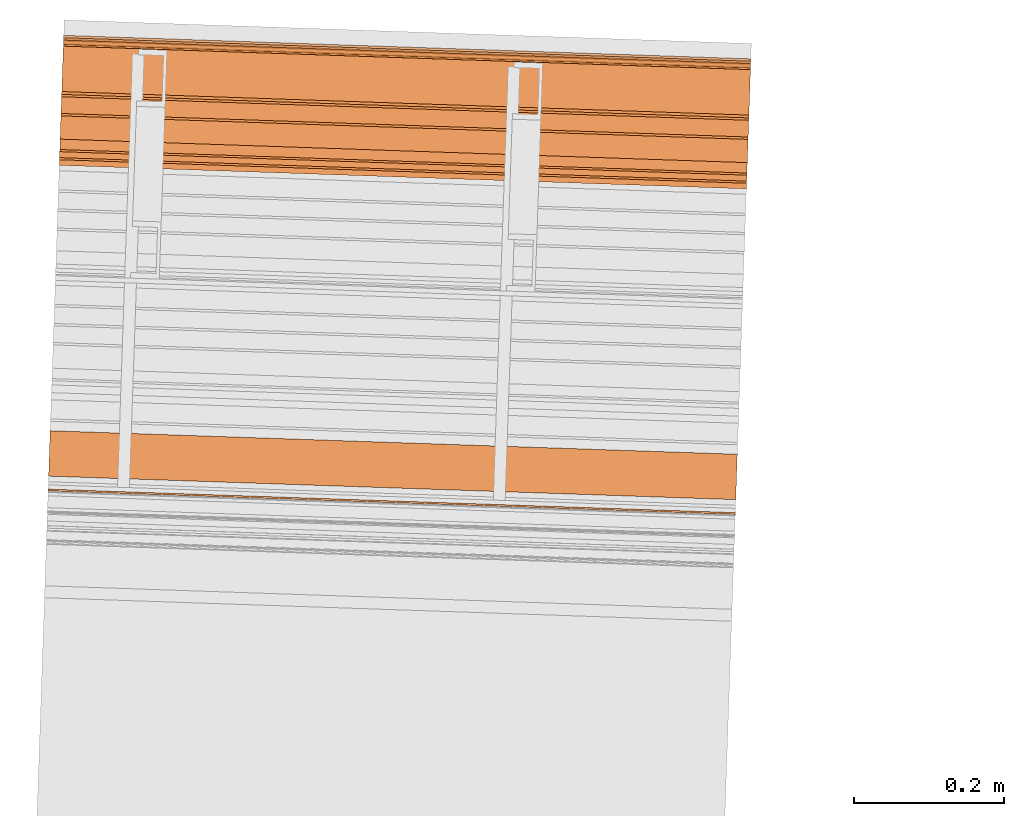
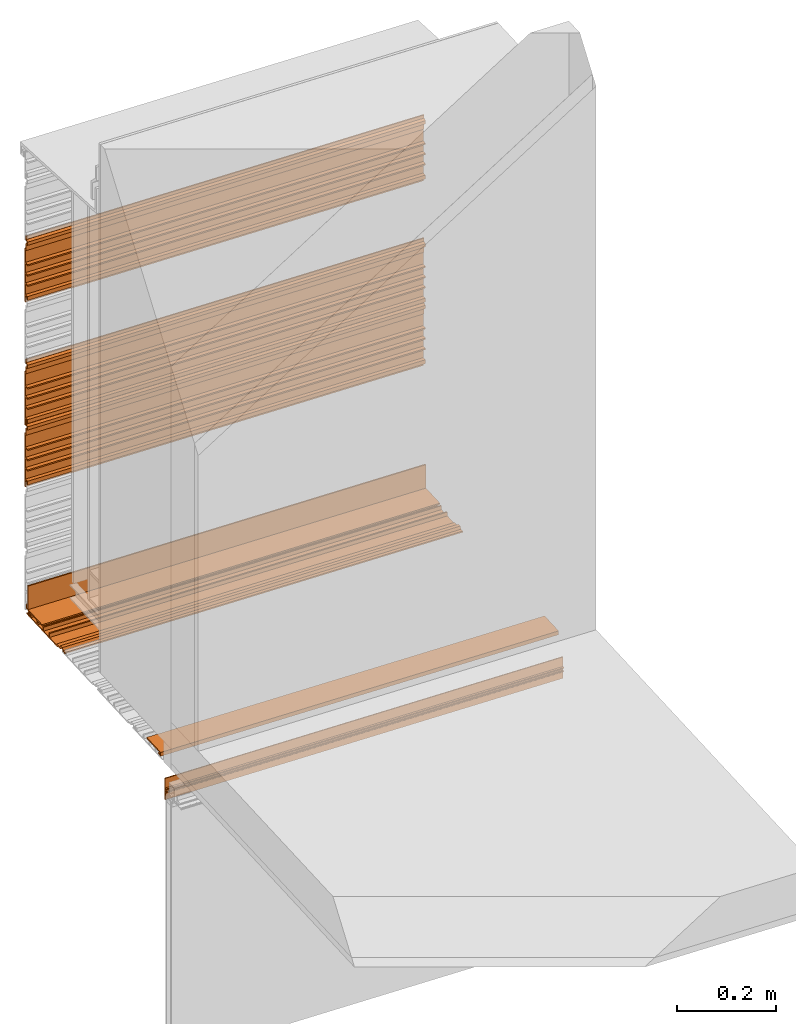
# One storey, part 5 of 6: 8 proxies.
"""IFC2X3 building model written with IfcOpenShell, lengths in feet."""

from ifc_helpers import new_model, entity, si_unit, converted_unit, derived_unit, direction, frame, frame_2d, origin, place, context, subcontext, project, spatial, polyline, circle_curve, parameter, trimmed, segment, composite_curve, outline, extrude, source, transform, mapped, material, type_object, type_shapes, element, save


model = new_model("IFC2X3")

# Units and contexts
model_context = context("Model", 3, precision=0.0001, world=origin(), true_north=direction((6.12303176911189e-17, 1.0)))
context_of_model = context(None, 3, precision=0.0001, world=origin(), true_north=direction((6.12303176911189e-17, 1.0)))
body_context = subcontext(model_context, "Body", "Model", "MODEL_VIEW")
ifc_project = project(units=[converted_unit("LENGTHUNIT", "FOOT", entity("IfcRatioMeasure", 0.3048), si_unit("LENGTHUNIT", "METRE"), dimensions=[1, 0, 0, 0, 0, 0, 0]), converted_unit("AREAUNIT", "SQUARE FOOT", entity("IfcRatioMeasure", 0.09290304), si_unit("AREAUNIT", "SQUARE_METRE"), dimensions=[2, 0, 0, 0, 0, 0, 0]), si_unit("VOLUMEUNIT", "CUBIC_METRE"), converted_unit("PLANEANGLEUNIT", "DEGREE", entity("IfcRatioMeasure", 0.0174532925199433), si_unit("PLANEANGLEUNIT", "RADIAN"), dimensions=[0, 0, 0, 0, 0, 0, 0]), si_unit("MASSUNIT", "GRAM", prefix="KILO"), derived_unit("MASSDENSITYUNIT", [(si_unit("MASSUNIT", "GRAM", prefix="KILO"), 1), (si_unit("LENGTHUNIT", "METRE"), -3)]), si_unit("TIMEUNIT", "SECOND"), si_unit("FREQUENCYUNIT", "HERTZ"), si_unit("THERMODYNAMICTEMPERATUREUNIT", "DEGREE_CELSIUS"), derived_unit("THERMALTRANSMITTANCEUNIT", [(si_unit("MASSUNIT", "GRAM", prefix="KILO"), 1), (si_unit("THERMODYNAMICTEMPERATUREUNIT", "KELVIN"), -1), (si_unit("TIMEUNIT", "SECOND"), -3)]), derived_unit("VOLUMETRICFLOWRATEUNIT", [(si_unit("LENGTHUNIT", "METRE"), 3), (si_unit("TIMEUNIT", "SECOND"), -1)]), si_unit("ELECTRICCURRENTUNIT", "AMPERE"), si_unit("ELECTRICVOLTAGEUNIT", "VOLT"), si_unit("POWERUNIT", "WATT"), si_unit("FORCEUNIT", "NEWTON"), si_unit("ILLUMINANCEUNIT", "LUX"), si_unit("LUMINOUSFLUXUNIT", "LUMEN"), si_unit("LUMINOUSINTENSITYUNIT", "CANDELA"), derived_unit("USERDEFINED", [(si_unit("MASSUNIT", "GRAM", prefix="KILO"), -1), (si_unit("LENGTHUNIT", "METRE"), -2), (si_unit("TIMEUNIT", "SECOND"), 3), (si_unit("LUMINOUSFLUXUNIT", "LUMEN"), 1)]), derived_unit("LINEARVELOCITYUNIT", [(si_unit("LENGTHUNIT", "METRE"), 1), (si_unit("TIMEUNIT", "SECOND"), -1)]), si_unit("PRESSUREUNIT", "PASCAL"), derived_unit("USERDEFINED", [(si_unit("LENGTHUNIT", "METRE"), -2), (si_unit("MASSUNIT", "GRAM", prefix="KILO"), 1), (si_unit("TIMEUNIT", "SECOND"), -2)])], contexts=[model_context, context_of_model])

# Site, building, storey
site_placement = place(None, origin())
site = spatial("IfcSite", under=ifc_project, at=site_placement, CompositionType="ELEMENT")
building_placement = place(site_placement, origin())
building = spatial("IfcBuilding", under=site, at=building_placement, CompositionType="ELEMENT")
storey_placement = place(building_placement, origin())
storey = spatial("IfcBuildingStorey", under=building, at=storey_placement, Name="Level 1", CompositionType="ELEMENT", Elevation=0.0)

# Proxies
ifc_material_1 = material()
building_element_proxy_type_1 = type_object("IfcBuildingElementProxyType", Name="panel 014", PredefinedType="NOTDEFINED", material=ifc_material_1)
shared_shape_1 = source(origin(), body_context, "Body", "SweptSolid", [
    extrude(outline(polyline([(-0.0220175316851953, 0.145680147068475), (-0.0220175316851953, -0.291819852931521), (-0.0116008650185187, -0.291819852931521), (-0.0116008650185187, -0.237132352931532), (0.00451787028331154, -0.237132352931532), (0.00451787028331154, -0.25796568626486), (0.0173047730392253, -0.25796568626486), (0.0173047730392253, -0.226715686264855), (-0.0116008650185187, -0.226715686264855), (-0.0116008650185187, -0.143382352931516), (0.0196491349814752, -0.143382352931516), (0.0196491349814752, -0.132965686264864), (-0.0116008650185187, -0.132965686264864), (-0.0116008650185187, -0.0600490195981784), (0.0196491349814752, -0.0600490195981784), (0.0196491349814752, -0.0496323529315248), (-0.0116008650185187, -0.0496323529315248), (-0.0116008650185187, 0.023284313735136), (0.0196491349814752, 0.023284313735136), (0.0196491349814752, 0.0337009804018127), (-0.0116008650185187, 0.0337009804018127), (-0.0116008650185187, 0.135263480401822), (-0.00118419835184916, 0.135263480401822), (-0.00118419835184916, 0.180710665113102), (0.0186287630982651, 0.189949600808633), (0.0186287630982651, 0.215994026661656), (-0.00118419835184916, 0.225232962029102), (-0.00118419835184916, 0.249846813735141), (-0.0116008650185187, 0.249846813735141), (-0.0116008650185187, 0.218596813735136), (0.0061931721533835, 0.210299318000239), (0.0061931721533835, 0.195644309470053), (-0.0116008650185187, 0.187346813735155), (-0.0116008650185187, 0.145680147068475), (-0.0220175316851953, 0.145680147068475)])), frame((109.785926286855, -48.5711433305344, 11.521009163627), z_axis=(-0.999414947916601, 0.034201781837477, 0.0), x_axis=(-0.034201781837477, -0.999414947916601, 0.0)), (0.0, 0.0, -1.0), 3.0),
])
type_shapes(building_element_proxy_type_1, [shared_shape_1])
proxy_1_placement = place(storey_placement, origin())
element("IfcBuildingElementProxy", 1, at=proxy_1_placement, inside=storey, type_object=building_element_proxy_type_1, material=ifc_material_1, Name="panel 014:panel 014", ObjectType="panel 014", context=body_context, shape_type="MappedRepresentation", body=[
    mapped(shared_shape_1, transform((0.0, 0.0, 0.0), scale=1.0)),
])
building_element_proxy_type_2 = type_object("IfcBuildingElementProxyType", Name="panel 016", PredefinedType="NOTDEFINED", material=ifc_material_1)
shared_shape_2 = source(origin(), body_context, "Body", "SweptSolid", [
    extrude(outline(polyline([(-0.291819852941177, -0.011600865003091), (-0.291819852941177, -0.0220175316697446), (0.145680147058838, -0.0220175316697446), (0.145680147058838, -0.011600865003091), (0.187346813725486, -0.011600865003091), (0.195644309526018, 0.00619317207041981), (0.21029931792497, 0.00619317207041981), (0.218596813725501, -0.011600865003091), (0.249846813725523, -0.011600865003091), (0.249846813725523, -0.00118419833641603), (0.225232962281936, -0.00118419833641603), (0.215994026619204, 0.0186287629496675), (0.189949600831812, 0.0186287629496675), (0.18071066516908, -0.00118419833641603), (0.135263480392162, -0.00118419833641603), (0.135263480392162, -0.011600865003091), (0.0337009803921564, -0.011600865003091), (0.0337009803921564, 0.0196491349969126), (0.0232843137255015, 0.0196491349969126), (0.0232843137255015, -0.011600865003091), (-0.049632352941162, -0.011600865003091), (-0.049632352941162, 0.0196491349969126), (-0.0600490196078382, 0.0196491349969126), (-0.0600490196078382, -0.011600865003091), (-0.132965686274501, -0.011600865003091), (-0.132965686274501, 0.0196491349969126), (-0.143382352941171, 0.0196491349969126), (-0.143382352941171, -0.011600865003091), (-0.22671568627451, -0.011600865003091), (-0.22671568627451, 0.0173047731202818), (-0.257965686274482, 0.0173047731202818), (-0.257965686274482, 0.00451787023313344), (-0.237132352941165, 0.00451787023313344), (-0.237132352941165, -0.011600865003091), (-0.291819852941177, -0.011600865003091)])), frame((109.775807895322, -48.8668142343156, 9.73037350903191), z_axis=(-0.999414947916631, 0.034201781836593, 0.0), x_axis=(-0.034201781836593, -0.999414947916631, 0.0)), (0.0, 0.0, -1.0), 2.99999999999999),
])
type_shapes(building_element_proxy_type_2, [shared_shape_2])
proxy_2_placement = place(storey_placement, origin())
element("IfcBuildingElementProxy", 2, at=proxy_2_placement, inside=storey, type_object=building_element_proxy_type_2, material=ifc_material_1, Name="panel 016:panel 016", ObjectType="panel 016", context=body_context, shape_type="MappedRepresentation", body=[
    mapped(shared_shape_2, transform((0.0, 0.0, 0.0), scale=1.0)),
])
building_element_proxy_type_3 = type_object("IfcBuildingElementProxyType", Name="panel 023", PredefinedType="NOTDEFINED", material=ifc_material_1)
shared_shape_3 = source(origin(), body_context, "Body", "SweptSolid", [
    extrude(outline(polyline([(-0.0220175316851953, 0.145680147068472), (-0.0220175316851953, -0.291819852931525), (-0.0116008650185187, -0.291819852931525), (-0.0116008650185187, -0.237132352931534), (0.00451787028331154, -0.237132352931534), (0.00451787028331154, -0.257965686264862), (0.0173047730392253, -0.257965686264862), (0.0173047730392253, -0.226715686264859), (-0.0116008650185187, -0.226715686264859), (-0.0116008650185187, -0.143382352931519), (0.0196491349814752, -0.143382352931519), (0.0196491349814752, -0.132965686264868), (-0.0116008650185187, -0.132965686264868), (-0.0116008650185187, -0.0600490195981802), (0.0196491349814752, -0.0600490195981802), (0.0196491349814752, -0.0496323529315283), (-0.0116008650185187, -0.0496323529315283), (-0.0116008650185187, 0.0232843137351324), (0.0196491349814752, 0.0232843137351324), (0.0196491349814752, 0.0337009804018091), (-0.0116008650185187, 0.0337009804018091), (-0.0116008650185187, 0.13526348040182), (-0.00118419835184916, 0.13526348040182), (-0.00118419835184916, 0.1807106651131), (0.0186287630982651, 0.189949600808632), (0.0186287630982651, 0.215994026661653), (-0.00118419835184916, 0.225232962029098), (-0.00118419835184916, 0.249846813735138), (-0.0116008650185187, 0.249846813735138), (-0.0116008650185187, 0.218596813735132), (0.0061931721533835, 0.210299318000235), (0.0061931721533835, 0.195644309470051), (-0.0116008650185187, 0.187346813735152), (-0.0116008650185187, 0.145680147068472), (-0.0220175316851953, 0.145680147068472)])), frame((109.785926286855, -48.5711433305344, 11.021009163627), z_axis=(-0.999414947916601, 0.034201781837477, 0.0), x_axis=(-0.034201781837477, -0.999414947916601, 0.0)), (0.0, 0.0, -1.0), 3.0),
])
type_shapes(building_element_proxy_type_3, [shared_shape_3])
proxy_3_placement = place(storey_placement, origin())
element("IfcBuildingElementProxy", 3, at=proxy_3_placement, inside=storey, type_object=building_element_proxy_type_3, material=ifc_material_1, Name="panel 023:panel 023", ObjectType="panel 023", context=body_context, shape_type="MappedRepresentation", body=[
    mapped(shared_shape_3, transform((0.0, 0.0, 0.0), scale=1.0)),
])
ifc_material_2 = material(Name="IfcSurfaceStyle #179")
building_element_proxy_type_4 = type_object("IfcBuildingElementProxyType", Name="starter strip 006", PredefinedType="NOTDEFINED", material=ifc_material_2)
shared_shape_4 = source(origin(), body_context, "Body", "SweptSolid", [
    extrude(outline(polyline([(-0.00592609117454079, -0.050489778625332), (-0.00592609117454079, -0.0251609571030116), (-0.0154211444225639, -0.0251609571030116), (-0.0154211444225639, -0.061359485646328), (0.015963096620743, -0.061359485646328), (0.015963096620743, 0.137010221374673), (0.00538413897639667, 0.137010221374673), (0.00538413897639667, -0.050489778625332), (-0.00592609117454079, -0.050489778625332)])), frame((109.785617492212, -48.5801666610631, 9.81008004634185), z_axis=(-0.999414947916641, 0.0342017818363039, 0.0), x_axis=(-0.0342017818363039, -0.999414947916641, 0.0)), (0.0, 0.0, -1.0), 2.99999999999999),
])
type_shapes(building_element_proxy_type_4, [shared_shape_4])
proxy_4_placement = place(storey_placement, origin())
element("IfcBuildingElementProxy", 4, at=proxy_4_placement, inside=storey, type_object=building_element_proxy_type_4, material=ifc_material_2, Name="starter strip 006:starter strip 006", ObjectType="starter strip 006", context=body_context, shape_type="MappedRepresentation", body=[
    mapped(shared_shape_4, transform((0.0, 0.0, 0.0), scale=1.0)),
])
building_element_proxy_type_5 = type_object("IfcBuildingElementProxyType", Name="panel 013", PredefinedType="NOTDEFINED", material=ifc_material_1)
shared_shape_5 = source(origin(), body_context, "Body", "SweptSolid", [
    extrude(outline(polyline([(-0.0220175316851953, 0.145680147068475), (-0.0220175316851953, -0.291819852931521), (-0.0116008650185187, -0.291819852931521), (-0.0116008650185187, -0.237132352931532), (0.00451787028331154, -0.237132352931532), (0.00451787028331154, -0.25796568626486), (0.0173047730392253, -0.25796568626486), (0.0173047730392253, -0.226715686264855), (-0.0116008650185187, -0.226715686264855), (-0.0116008650185187, -0.143382352931518), (0.0196491349814752, -0.143382352931518), (0.0196491349814752, -0.132965686264864), (-0.0116008650185187, -0.132965686264864), (-0.0116008650185187, -0.0600490195981784), (0.0196491349814752, -0.0600490195981784), (0.0196491349814752, -0.0496323529315248), (-0.0116008650185187, -0.0496323529315248), (-0.0116008650185187, 0.023284313735136), (0.0196491349814752, 0.023284313735136), (0.0196491349814752, 0.0337009804018109), (-0.0116008650185187, 0.0337009804018109), (-0.0116008650185187, 0.135263480401822), (-0.00118419835184916, 0.135263480401822), (-0.00118419835184916, 0.180710665113102), (0.0186287630982651, 0.189949600808633), (0.0186287630982651, 0.215994026661654), (-0.00118419835184916, 0.225232962029102), (-0.00118419835184916, 0.24984681373514), (-0.0116008650185187, 0.24984681373514), (-0.0116008650185187, 0.218596813735136), (0.0061931721533835, 0.210299318000237), (0.0061931721533835, 0.195644309470053), (-0.0116008650185187, 0.187346813735155), (-0.0116008650185187, 0.145680147068475), (-0.0220175316851953, 0.145680147068475)])), frame((109.785926286855, -48.5711433305344, 12.521009163627), z_axis=(-0.999414947916601, 0.034201781837477, 0.0), x_axis=(-0.034201781837477, -0.999414947916601, 0.0)), (0.0, 0.0, -1.0), 3.0),
])
type_shapes(building_element_proxy_type_5, [shared_shape_5])
proxy_5_placement = place(storey_placement, origin())
element("IfcBuildingElementProxy", 5, at=proxy_5_placement, inside=storey, type_object=building_element_proxy_type_5, material=ifc_material_1, Name="panel 013:panel 013", ObjectType="panel 013", context=body_context, shape_type="MappedRepresentation", body=[
    mapped(shared_shape_5, transform((0.0, 0.0, 0.0), scale=1.0)),
])
building_element_proxy_type_6 = type_object("IfcBuildingElementProxyType", Name="starter strip 004", PredefinedType="NOTDEFINED", material=ifc_material_2)
shared_shape_6 = source(origin(), body_context, "Body", "SweptSolid", [
    extrude(outline(polyline([(-0.0154211442749261, -0.0613594857283405), (0.0159630965387123, -0.0613594857283405), (0.0159630965387123, 0.137010221423876), (0.00538413886154032, 0.137010221423876), (0.00538413886154032, -0.0504897785761173), (-0.00592609112533005, -0.0504897785761173), (-0.00592609112533005, -0.0251609571194176), (-0.0154211442749261, -0.0251609571194176), (-0.0154211442749261, -0.0613594857283405)])), frame((109.782968627618, -48.657569495894, 9.74081747039039), z_axis=(0.999414947916646, -0.0342017818361628, 0.0), x_axis=(0.0, 0.0, 1.0)), (0.0, 0.0, 1.0), 3.0),
])
type_shapes(building_element_proxy_type_6, [shared_shape_6])
proxy_6_placement = place(storey_placement, origin())
element("IfcBuildingElementProxy", 6, at=proxy_6_placement, inside=storey, type_object=building_element_proxy_type_6, material=ifc_material_2, Name="starter strip 004:starter strip 004", ObjectType="starter strip 004", context=body_context, shape_type="MappedRepresentation", body=[
    mapped(shared_shape_6, transform((0.0, 0.0, 0.0), scale=1.0)),
])
building_element_proxy_type_7 = type_object("IfcBuildingElementProxyType", Name="starter strip 005", PredefinedType="NOTDEFINED", material=ifc_material_2)
shared_shape_7 = source(origin(), body_context, "Body", "SweptSolid", [
    extrude(outline(polyline([(-0.00592609117455467, -0.050489778625324), (-0.00592609117455467, -0.0251609571030094), (-0.0154211444225663, -0.0251609571030094), (-0.0154211444225663, -0.0613594856463255), (0.0159630966207374, -0.0613594856463255), (0.0159630966207374, 0.13701022137468), (0.00538413897638179, 0.13701022137468), (0.00538413897638179, -0.050489778625324), (-0.00592609117455467, -0.050489778625324)])), frame((109.722955483837, -50.4112217837229, 9.74081747030829), z_axis=(-0.999414947916628, 0.0342017818366754, 0.0), x_axis=(0.0, 0.0, 1.0)), (0.0, 0.0, -1.0), 3.0),
])
type_shapes(building_element_proxy_type_7, [shared_shape_7])
proxy_7_placement = place(storey_placement, origin())
element("IfcBuildingElementProxy", 7, at=proxy_7_placement, inside=storey, type_object=building_element_proxy_type_7, material=ifc_material_2, Name="starter strip 005:starter strip 005", ObjectType="starter strip 005", context=body_context, shape_type="MappedRepresentation", body=[
    mapped(shared_shape_7, transform((0.0, 0.0, 0.0), scale=1.0)),
])
ifc_material_3 = material(Name="Window frame")
building_element_proxy_type_8 = type_object("IfcBuildingElementProxyType", Name="Window frame 016", PredefinedType="NOTDEFINED", material=ifc_material_3)
shared_shape_8 = source(origin(), body_context, "Body", "SweptSolid", [
    extrude(outline(composite_curve([segment(trimmed(circle_curve(frame_2d((0.00560116958344474, -0.0105069444443782), x_axis=(1.0, 0.0)), 0.00208333333333355), [parameter(359.999999999951)], [parameter(180.0)], True, "PARAMETER"), True, "CONTINUOUS"), segment(trimmed(circle_curve(frame_2d((0.00143450291647657, -0.0105069444443782), x_axis=(1.0, 0.0)), 0.00208333333333194), [parameter(270.0)], [parameter(0.0)], True, "PARAMETER"), False, "CONTINUOUS"), segment(polyline([(0.00143450291647657, -0.0125902777777096), (-0.00206549708348842, -0.0125902777778002)]), True, "CONTINUOUS"), segment(trimmed(circle_curve(frame_2d((-0.00206549708348842, -0.0105069444443782), x_axis=(1.0, 0.0)), 0.00208333333333249), [parameter(180.0)], [parameter(270.0)], True, "PARAMETER"), False, "CONTINUOUS"), segment(polyline([(-0.00414883041681959, -0.0105069444443782), (-0.00414883041661929, 0.00999305555563446)]), True, "CONTINUOUS"), segment(trimmed(circle_curve(frame_2d((-0.00206549708348745, 0.00999305555563446), x_axis=(1.0, 0.0)), 0.00208333333333313), [parameter(90.0000000000001)], [parameter(180.0)], True, "PARAMETER"), False, "CONTINUOUS"), segment(polyline([(-0.00206549708348745, 0.0120763888889677), (0.00143450291647803, 0.0120763888888664)]), True, "CONTINUOUS"), segment(trimmed(circle_curve(frame_2d((0.00143450291647803, 0.00999305555563446), x_axis=(1.0, 0.0)), 0.00208333333333237), [parameter(0.0)], [parameter(90.0000000000001)], True, "PARAMETER"), False, "CONTINUOUS"), segment(trimmed(circle_curve(frame_2d((0.00560116958344571, 0.00999305555563446), x_axis=(1.0, 0.0)), 0.00208333333333355), [parameter(180.0)], [parameter(0.0)], True, "PARAMETER"), True, "CONTINUOUS"), segment(polyline([(0.00768450291677688, 0.00999305555563446), (0.00768450291672007, 0.0146597222220066)]), True, "CONTINUOUS"), segment(trimmed(circle_curve(frame_2d((0.00510116958329158, 0.0146597222220066), x_axis=(1.0, 0.0)), 0.00258333333333234), [parameter(0.0)], [parameter(90.0000000000001)], True, "PARAMETER"), True, "CONTINUOUS"), segment(polyline([(0.00510116958329158, 0.0172430555553387), (-0.00231549708326933, 0.0172430555555323)]), True, "CONTINUOUS"), segment(polyline([(-0.00231549708326933, 0.0172430555555323), (-0.00231549708326642, 0.0755763888888659)]), True, "CONTINUOUS"), segment(polyline([(-0.00231549708326642, 0.0755763888888659), (-0.00748216374994586, 0.0755763888888659)]), True, "CONTINUOUS"), segment(polyline([(-0.00748216374994586, 0.0755763888888659), (-0.00748216374994586, 0.0797430555555323)]), True, "CONTINUOUS"), segment(polyline([(-0.00748216374994586, 0.0797430555555323), (-0.0108154970832829, 0.0797430555555323)]), True, "CONTINUOUS"), segment(polyline([(-0.0108154970832829, 0.0797430555555323), (-0.0108154970832846, -0.0973402777777999)]), True, "CONTINUOUS"), segment(polyline([(-0.0108154970832846, -0.0973402777777999), (-0.00306549708326136, -0.0973402777777999)]), True, "CONTINUOUS"), segment(polyline([(-0.00306549708326136, -0.0973402777777999), (-0.00414883041661753, -0.0921736111111322)]), True, "CONTINUOUS"), segment(polyline([(-0.00414883041661753, -0.0921736111111322), (-0.00414883041662075, -0.0192569444444661)]), True, "CONTINUOUS"), segment(polyline([(-0.00414883041662075, -0.0192569444444661), (0.00642309958337842, -0.0192569444444661)]), True, "CONTINUOUS"), segment(polyline([(0.00642309958337842, -0.0192569444444661), (0.0102678362500619, -0.0192569444444661)]), True, "CONTINUOUS"), segment(polyline([(0.0102678362500619, -0.0192569444444661), (0.0102678362500624, -0.0125902777778002)]), True, "CONTINUOUS"), segment(polyline([(0.0102678362500624, -0.0125902777778002), (0.00768450291677591, -0.0105069444443782)]), True, "CONTINUOUS")], self_intersect=False)), frame((109.718553820177, -50.5398433999572, 9.48804422127076), z_axis=(0.999414947916632, -0.0342017818365531, 0.0), x_axis=(-0.0342017818365531, -0.999414947916632, 0.0)), (0.0, 0.0, 1.0), 3.0),
])
type_shapes(building_element_proxy_type_8, [shared_shape_8])
proxy_8_placement = place(storey_placement, origin())
element("IfcBuildingElementProxy", 8, at=proxy_8_placement, inside=storey, type_object=building_element_proxy_type_8, material=ifc_material_3, Name="Window frame 016:Window frame 016", ObjectType="Window frame 016", context=body_context, shape_type="MappedRepresentation", body=[
    mapped(shared_shape_8, transform((0.0, 0.0, 0.0), scale=1.0)),
])

save(model, "model.ifc")
